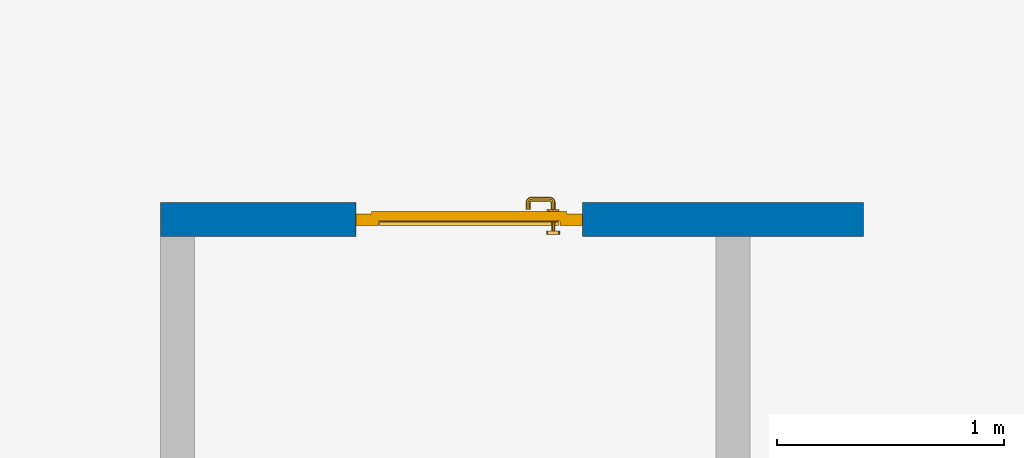
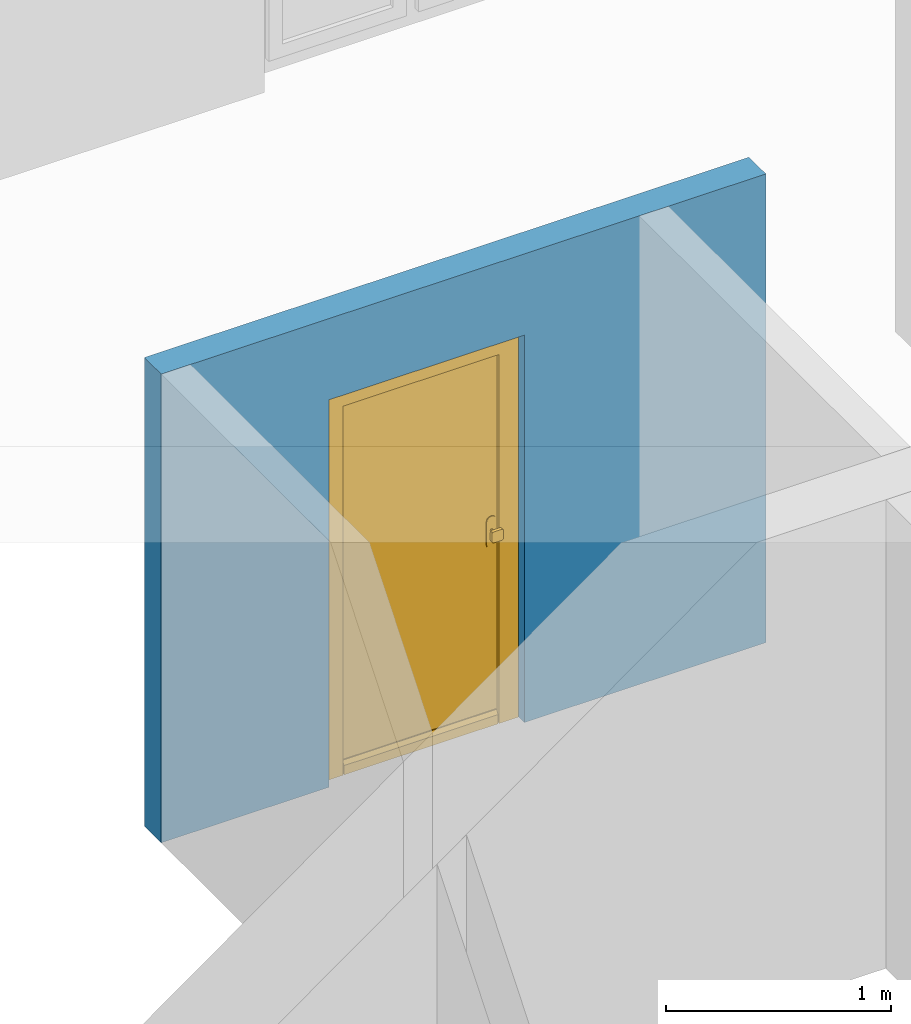
# One storey, part 11 of 48: 1 door, 1 wall, 1 opening.
"""IFC4 building model written with IfcOpenShell, lengths in metres."""

from ifc_helpers import new_model, entity, si_unit, converted_unit, derived_unit, direction, frame, origin_with_axes, place, context, subcontext, project, spatial, polygons, source, transform, mapped, material, type_object, element, fill, save


model = new_model("IFC4")

# Units and contexts
model_context = context("Model", 3, precision=1e-05, world=origin_with_axes(), true_north=direction((0.0, 1.0)))
body_context = subcontext(model_context, "Body", "Model", "MODEL_VIEW")
ifc_project = project(units=[si_unit("LENGTHUNIT", "METRE"), si_unit("AREAUNIT", "SQUARE_METRE"), si_unit("VOLUMEUNIT", "CUBIC_METRE"), converted_unit("PLANEANGLEUNIT", "DEGREE", entity("IfcPlaneAngleMeasure", 0.0174532925199), si_unit("PLANEANGLEUNIT", "RADIAN"), dimensions=[0, 0, 0, 0, 0, 0, 0]), converted_unit("TIMEUNIT", "Year", entity("IfcTimeMeasure", 31556926.0), si_unit("TIMEUNIT", "SECOND"), dimensions=[0, 0, 1, 0, 0, 0, 0]), si_unit("MASSUNIT", "GRAM", prefix="KILO"), si_unit("THERMODYNAMICTEMPERATUREUNIT", "DEGREE_CELSIUS"), si_unit("LUMINOUSINTENSITYUNIT", "LUMEN"), si_unit("ENERGYUNIT", "JOULE", prefix="MEGA"), derived_unit("THERMALCONDUCTANCEUNIT", [(si_unit("POWERUNIT", "WATT"), 1), (si_unit("LENGTHUNIT", "METRE"), -1), (si_unit("THERMODYNAMICTEMPERATUREUNIT", "KELVIN"), -1)]), derived_unit("SPECIFICHEATCAPACITYUNIT", [(si_unit("ENERGYUNIT", "JOULE"), 1), (si_unit("MASSUNIT", "GRAM", prefix="KILO"), -1), (si_unit("THERMODYNAMICTEMPERATUREUNIT", "KELVIN"), -1)]), derived_unit("MASSDENSITYUNIT", [(si_unit("MASSUNIT", "GRAM", prefix="KILO"), 1), (si_unit("VOLUMEUNIT", "CUBIC_METRE"), -1)])], contexts=[model_context])

# Site, building, storey
site_placement = place(None, origin_with_axes())
site = spatial("IfcSite", under=ifc_project, at=site_placement, CompositionType="ELEMENT")
building_placement = place(site_placement, origin_with_axes())
building = spatial("IfcBuilding", under=site, at=building_placement, CompositionType="ELEMENT")
storey_placement = place(building_placement, frame((0.0, 0.0, 3.4), z_axis=(0.0, 0.0, 1.0), x_axis=(1.0, 0.0, 0.0)))
storey = spatial("IfcBuildingStorey", under=building, at=storey_placement, Name="1. Geschoss", CompositionType="ELEMENT", Elevation=3.4)

# Wall, opening, door
ifc_material = material()
wall_type = type_object("IfcWallType", Name="150", PredefinedType="NOTDEFINED")
wall_placement = place(storey_placement, frame((-4.4421993804, 3.97118776896, 0.0), z_axis=(0.0, 0.0, 1.0), x_axis=(-1.0, 0.0, 0.0)))
wall = element("IfcWall", 1, at=wall_placement, inside=storey, type_object=wall_type, material=ifc_material, Name="Wand-002", PredefinedType="NOTDEFINED", context=body_context, shape_type="Tessellation", body=[
    polygons([(2.23891244988, 0.0, 2.1), (2.23891244988, 0.0, 0.0), (3.1, 0.0, 0.0), (3.1, 0.0, 2.54), (0.0, 0.0, 2.54), (0.0, 0.0, 0.0), (1.23891244988, 0.0, 0.0), (1.23891244988, 0.0, 2.1), (2.23891244988, 0.1, 2.1), (2.23891244988, 0.1, 0.0), (2.23891244988, 0.15, 0.0), (3.1, 0.15, 0.0), (3.1, 0.15, 2.54), (0.0, 0.15, 2.54), (0.0, 0.15, 0.0), (1.23891244988, 0.1, 0.0), (1.23891244988, 0.15, 0.0), (1.23891244988, 0.1, 2.1), (2.23891244988, 0.15, 2.1), (1.23891244988, 0.15, 2.1)], [[[1, 2, 3, 4, 5, 6, 7, 8]], [[2, 1, 9, 10]], [[2, 10, 11, 12, 3]], [[4, 3, 12, 13]], [[5, 4, 13, 14]], [[14, 15, 6, 5]], [[16, 7, 6, 15, 17]], [[8, 7, 16, 18]], [[1, 8, 18, 9]], [[10, 9, 19, 11]], [[12, 11, 19, 20, 17, 15, 14, 13]], [[18, 16, 17, 20]], [[9, 18, 20, 19]]], closed=True),
])
opening_placement = place(wall_placement, frame((1.73891244988, 0.0, 0.0), z_axis=(0.0, 0.0, 1.0), x_axis=(1.0, 0.0, 0.0)))
opening = element("IfcOpeningElement", 2, at=opening_placement, cuts=wall, context=body_context, identifier="Reference", shape_type="Tessellation", body=[
    polygons([(-0.5, 0.1, 0.0), (-0.5, 0.1, 2.1), (-0.5, 0.151, 2.1), (-0.5, 0.151, 0.0), (-0.5, -0.001, 0.0), (-0.5, -0.001, 2.1), (0.5, 0.1, 2.1), (0.5, 0.151, 2.1), (0.5, -0.001, 2.1), (0.5, 0.151, 0.0), (0.5, 0.1, 0.0), (0.5, -0.001, 0.0)], [[[1, 2, 3, 4]], [[2, 1, 5, 6]], [[7, 8, 3, 2, 6, 9]], [[8, 10, 4, 3]], [[1, 4, 10, 11, 12, 5]], [[6, 5, 12, 9]], [[7, 11, 10, 8]], [[11, 7, 9, 12]]], closed=True),
])
door_type = type_object("IfcDoorType", Name="Eingang 01 1-Fl 26", OperationType="SINGLE_SWING_LEFT", PredefinedType="DOOR")
shared_shape = source(origin_with_axes(), body_context, "Body", "Tessellation", [
    polygons([(-0.5, -0.05, 0.0), (-0.5, -0.05, 2.1), (-0.5, -0.03, 2.1), (-0.5, -0.03, 0.0), (-0.4, -0.05, 0.0), (-0.4, -0.05, 2.0), (-0.1301, -0.05, 2.0), (-0.0001, -0.05, 2.0), (0.4, -0.05, 2.0), (0.4, -0.05, 0.0), (0.5, -0.05, 0.0), (0.5, -0.05, 2.1), (0.5, -0.03, 2.1), (0.5, -0.03, 0.0), (0.4, -0.03, 0.0), (0.4, -0.03, 2.0), (-0.0001, -0.03, 2.0), (-0.1301, -0.03, 2.0), (-0.4, -0.03, 2.0), (-0.4, -0.03, 0.0)], [[[1, 2, 3, 4]], [[1, 5, 6, 7, 8, 9, 10, 11, 12, 2]], [[2, 12, 13, 3]], [[4, 3, 13, 14, 15, 16, 17, 18, 19, 20]], [[5, 1, 4, 20]], [[6, 5, 20, 19]], [[7, 6, 19, 18]], [[8, 7, 18, 17]], [[9, 8, 17, 16]], [[10, 9, 16, 15]], [[11, 10, 15, 14]], [[12, 11, 14, 13]]], closed=True),
    polygons([(-0.5, -0.03, 0.0), (-0.5, -0.03, 2.1), (-0.5, 0.0, 2.1), (-0.5, 0.0, 0.0), (-0.43, -0.03, 0.0), (-0.43, -0.03, 2.03), (-0.1001, -0.03, 2.03), (-0.0301, -0.03, 2.03), (0.43, -0.03, 2.03), (0.43, -0.03, 0.0), (0.5, -0.03, 0.0), (0.5, -0.03, 2.1), (0.5, 0.0, 2.1), (0.5, 0.0, 0.0), (0.43, 0.0, 0.0), (0.43, 0.0, 2.03), (-0.0301, 0.0, 2.03), (-0.1001, 0.0, 2.03), (-0.43, 0.0, 2.03), (-0.43, 0.0, 0.0)], [[[1, 2, 3, 4]], [[1, 5, 6, 7, 8, 9, 10, 11, 12, 2]], [[2, 12, 13, 3]], [[4, 3, 13, 14, 15, 16, 17, 18, 19, 20]], [[5, 1, 4, 20]], [[6, 5, 20, 19]], [[7, 6, 19, 18]], [[8, 7, 18, 17]], [[9, 8, 17, 16]], [[10, 9, 16, 15]], [[11, 10, 15, 14]], [[12, 11, 14, 13]]], closed=True),
    polygons([(-0.43, 0.01, 0.0), (-0.43, 0.01, 2.03), (0.43, 0.01, 2.03), (0.43, 0.01, 0.0), (-0.43, -0.03, 0.0), (-0.43, -0.03, 2.03), (0.43, -0.03, 2.03), (0.43, -0.03, 0.0)], [[[1, 2, 3, 4]], [[1, 5, 6, 2]], [[2, 6, 7, 3]], [[3, 7, 8, 4]], [[4, 8, 5, 1]], [[8, 7, 6, 5]]], closed=True),
    polygons([(-0.395, -0.05, 0.0), (0.395, -0.05, 0.0), (0.395, -0.05, 0.05), (-0.395, -0.05, 0.05), (-0.395, -0.03, 0.0), (0.395, -0.03, 0.0), (0.395, -0.03, 0.07), (0.395, -0.035, 0.07), (-0.395, -0.035, 0.07), (-0.395, -0.03, 0.07)], [[[1, 2, 3, 4]], [[5, 6, 2, 1]], [[2, 6, 7, 8, 3]], [[4, 3, 8, 9]], [[1, 4, 9, 10, 5]], [[10, 7, 6, 5]], [[9, 8, 7, 10]]], closed=True),
    polygons([(0.3835, 0.02, 1.0733826859), (0.37, 0.02, 1.077), (0.37, 0.0199, 1.077), (0.3835, 0.0199, 1.0733826859), (0.393382685902, 0.02, 1.0635), (0.397, 0.02, 1.05), (0.393382685902, 0.02, 1.0365), (0.3835, 0.02, 1.0266173141), (0.37, 0.02, 1.023), (0.3565, 0.02, 1.0266173141), (0.346617314098, 0.02, 1.0365), (0.343, 0.02, 1.05), (0.346617314098, 0.02, 1.0635), (0.3565, 0.02, 1.0733826859), (0.3565, 0.0199, 1.0733826859), (0.37, 0.0101, 1.077), (0.3835, 0.0101, 1.0733826859), (0.393382685902, 0.0199, 1.0635), (0.397, 0.0199, 1.05), (0.393382685902, 0.0199, 1.0365), (0.3835, 0.0199, 1.0266173141), (0.37, 0.0199, 1.023), (0.3565, 0.0199, 1.0266173141), (0.346617314098, 0.0199, 1.0365), (0.343, 0.0199, 1.05), (0.346617314098, 0.0199, 1.0635), (0.3565, 0.0101, 1.0733826859), (0.37, 0.01, 1.077), (0.3835, 0.01, 1.0733826859), (0.393382685902, 0.0101, 1.0635), (0.397, 0.0101, 1.05), (0.393382685902, 0.0101, 1.0365), (0.3835, 0.0101, 1.0266173141), (0.37, 0.0101, 1.023), (0.3565, 0.0101, 1.0266173141), (0.346617314098, 0.0101, 1.0365), (0.343, 0.0101, 1.05), (0.346617314098, 0.0101, 1.0635), (0.3565, 0.01, 1.0733826859), (0.346617314098, 0.01, 1.0635), (0.343, 0.01, 1.05), (0.346617314098, 0.01, 1.0365), (0.3565, 0.01, 1.0266173141), (0.37, 0.01, 1.023), (0.3835, 0.01, 1.0266173141), (0.393382685902, 0.01, 1.0365), (0.397, 0.01, 1.05), (0.393382685902, 0.01, 1.0635)], [[[1, 2, 3, 4]], [[2, 1, 5, 6, 7, 8, 9, 10, 11, 12, 13, 14]], [[2, 14, 15, 3]], [[4, 3, 16, 17]], [[5, 1, 4, 18]], [[6, 5, 18, 19]], [[7, 6, 19, 20]], [[8, 7, 20, 21]], [[9, 8, 21, 22]], [[10, 9, 22, 23]], [[11, 10, 23, 24]], [[12, 11, 24, 25]], [[13, 12, 25, 26]], [[14, 13, 26, 15]], [[3, 15, 27, 16]], [[17, 16, 28, 29]], [[18, 4, 17, 30]], [[19, 18, 30, 31]], [[20, 19, 31, 32]], [[21, 20, 32, 33]], [[22, 21, 33, 34]], [[23, 22, 34, 35]], [[24, 23, 35, 36]], [[25, 24, 36, 37]], [[26, 25, 37, 38]], [[15, 26, 38, 27]], [[16, 27, 39, 28]], [[28, 39, 40, 41, 42, 43, 44, 45, 46, 47, 48, 29]], [[30, 17, 29, 48]], [[31, 30, 48, 47]], [[32, 31, 47, 46]], [[33, 32, 46, 45]], [[34, 33, 45, 44]], [[35, 34, 44, 43]], [[36, 35, 43, 42]], [[37, 36, 42, 41]], [[38, 37, 41, 40]], [[27, 38, 40, 39]]], closed=True),
    polygons([(0.362532169224, 0.019, 0.959692280177), (0.363279754556, 0.019, 0.961639806549), (0.35705, 0.019, 0.972430057958), (0.347569942042, 0.019, 0.96295), (0.365, 0.019, 0.952886751346), (0.365, 0.019, 0.9544), (0.362532169224, 0.02, 0.959692280177), (0.363279754556, 0.02, 0.961639806549), (0.364624817685, 0.02, 0.965143815798), (0.364624817685, 0.019, 0.965143815798), (0.37, 0.019, 0.967425445323), (0.37, 0.019, 0.9759), (0.357, 0.019, 0.972516660498), (0.347483339502, 0.019, 0.963), (0.365, 0.019, 0.95), (0.3441, 0.019, 0.95), (0.365, 0.019, 0.947113248654), (0.365, 0.019, 0.941339745962), (0.365, 0.019, 0.9375), (0.365, 0.02, 0.9375), (0.365, 0.02, 0.941339745962), (0.365, 0.02, 0.947113248654), (0.365, 0.02, 0.95), (0.365, 0.02, 0.952886751346), (0.365, 0.02, 0.9544), (0.346703916638, 0.02, 0.96345), (0.35655, 0.02, 0.973296083362), (0.37, 0.02, 0.9769), (0.37, 0.02, 0.967425445323), (0.375375182315, 0.019, 0.965143815798), (0.376720245444, 0.019, 0.961639806549), (0.38295, 0.019, 0.972430057958), (0.37, 0.019, 0.976), (0.357, 0.0189, 0.972516660498), (0.347483339502, 0.0189, 0.963), (0.344, 0.019, 0.95), (0.347569942042, 0.019, 0.93705), (0.35705, 0.019, 0.927569942042), (0.37, 0.019, 0.9241), (0.37, 0.019, 0.9325), (0.366464466094, 0.019, 0.933964466094), (0.366464466094, 0.02, 0.933964466094), (0.37, 0.02, 0.9231), (0.35655, 0.02, 0.926703916638), (0.37, 0.02, 0.9325), (0.346703916638, 0.02, 0.93655), (0.3431, 0.02, 0.95), (0.346617314098, 0.02, 0.9635), (0.3565, 0.02, 0.973382685902), (0.37, 0.02, 0.977), (0.375375182315, 0.02, 0.965143815798), (0.38345, 0.02, 0.973296083362), (0.376720245444, 0.02, 0.961639806549), (0.377467830776, 0.02, 0.959692280177), (0.377467830776, 0.019, 0.959692280177), (0.375, 0.019, 0.9544), (0.375, 0.019, 0.952886751346), (0.392430057958, 0.019, 0.96295), (0.383, 0.019, 0.972516660498), (0.37, 0.0189, 0.976), (0.357, 0.0101, 0.972516660498), (0.347483339502, 0.0101, 0.963), (0.344, 0.0189, 0.95), (0.347483339502, 0.019, 0.937), (0.357, 0.019, 0.927483339502), (0.37, 0.019, 0.924), (0.38295, 0.019, 0.927569942042), (0.375, 0.019, 0.941339745962), (0.375, 0.019, 0.9375), (0.373535533906, 0.019, 0.933964466094), (0.37, 0.02, 0.923), (0.3565, 0.02, 0.926617314098), (0.38345, 0.02, 0.926703916638), (0.373535533906, 0.02, 0.933964466094), (0.375, 0.02, 0.9375), (0.375, 0.02, 0.941339745962), (0.346617314098, 0.02, 0.9365), (0.343, 0.02, 0.95), (0.346617314098, 0.0199, 0.9635), (0.3565, 0.0199, 0.973382685902), (0.37, 0.0199, 0.977), (0.3835, 0.02, 0.973382685902), (0.393296083362, 0.02, 0.96345), (0.375, 0.02, 0.952886751346), (0.375, 0.02, 0.9544), (0.375, 0.02, 0.95), (0.375, 0.02, 0.947113248654), (0.375, 0.019, 0.947113248654), (0.375, 0.019, 0.95), (0.3959, 0.019, 0.95), (0.392516660498, 0.019, 0.963), (0.383, 0.0189, 0.972516660498), (0.37, 0.0101, 0.976), (0.357, 0.01, 0.972516660498), (0.347483339502, 0.01, 0.963), (0.344, 0.0101, 0.95), (0.347483339502, 0.0189, 0.937), (0.357, 0.0189, 0.927483339502), (0.37, 0.0189, 0.924), (0.383, 0.019, 0.927483339502), (0.392430057958, 0.019, 0.93705), (0.37, 0.0199, 0.923), (0.3565, 0.0199, 0.926617314098), (0.3835, 0.02, 0.926617314098), (0.393296083362, 0.02, 0.93655), (0.346617314098, 0.0199, 0.9365), (0.343, 0.0199, 0.95), (0.346617314098, 0.0101, 0.9635), (0.3565, 0.0101, 0.973382685902), (0.37, 0.0101, 0.977), (0.3835, 0.0199, 0.973382685902), (0.393382685902, 0.02, 0.9635), (0.3969, 0.02, 0.95), (0.396, 0.019, 0.95), (0.392516660498, 0.0189, 0.963), (0.383, 0.0101, 0.972516660498), (0.37, 0.01, 0.976), (0.35695, 0.01, 0.972603263039), (0.347396736961, 0.01, 0.96305), (0.344, 0.01, 0.95), (0.347483339502, 0.0101, 0.937), (0.357, 0.0101, 0.927483339502), (0.37, 0.0101, 0.924), (0.383, 0.0189, 0.927483339502), (0.392516660498, 0.019, 0.937), (0.37, 0.0101, 0.923), (0.3565, 0.0101, 0.926617314098), (0.3835, 0.0199, 0.926617314098), (0.393382685902, 0.02, 0.9365), (0.346617314098, 0.0101, 0.9365), (0.343, 0.0101, 0.95), (0.346617314098, 0.01, 0.9635), (0.3565, 0.01, 0.973382685902), (0.37, 0.01, 0.977), (0.3835, 0.0101, 0.973382685902), (0.393382685902, 0.0199, 0.9635), (0.397, 0.02, 0.95), (0.396, 0.0189, 0.95), (0.392516660498, 0.0101, 0.963), (0.383, 0.01, 0.972516660498), (0.37, 0.01, 0.9761), (0.35655, 0.01, 0.973296083362), (0.346703916638, 0.01, 0.96345), (0.3439, 0.01, 0.95), (0.347483339502, 0.01, 0.937), (0.357, 0.01, 0.927483339502), (0.37, 0.01, 0.924), (0.383, 0.0101, 0.927483339502), (0.392516660498, 0.0189, 0.937), (0.37, 0.01, 0.923), (0.3565, 0.01, 0.926617314098), (0.3835, 0.0101, 0.926617314098), (0.393382685902, 0.0199, 0.9365), (0.346617314098, 0.01, 0.9365), (0.343, 0.01, 0.95), (0.37, 0.01, 0.9769), (0.3835, 0.01, 0.973382685902), (0.393382685902, 0.0101, 0.9635), (0.397, 0.0199, 0.95), (0.396, 0.0101, 0.95), (0.392516660498, 0.01, 0.963), (0.38305, 0.01, 0.972603263039), (0.3431, 0.01, 0.95), (0.347396736961, 0.01, 0.93695), (0.35695, 0.01, 0.927396736961), (0.37, 0.01, 0.9239), (0.383, 0.01, 0.927483339502), (0.392516660498, 0.0101, 0.937), (0.37, 0.01, 0.9231), (0.35655, 0.01, 0.926703916638), (0.3835, 0.01, 0.926617314098), (0.393382685902, 0.0101, 0.9365), (0.346703916638, 0.01, 0.93655), (0.38345, 0.01, 0.973296083362), (0.393382685902, 0.01, 0.9635), (0.397, 0.0101, 0.95), (0.396, 0.01, 0.95), (0.392603263039, 0.01, 0.96305), (0.38305, 0.01, 0.927396736961), (0.392516660498, 0.01, 0.937), (0.38345, 0.01, 0.926703916638), (0.393382685902, 0.01, 0.9365), (0.393296083362, 0.01, 0.96345), (0.397, 0.01, 0.95), (0.3961, 0.01, 0.95), (0.392603263039, 0.01, 0.93695), (0.393296083362, 0.01, 0.93655), (0.3969, 0.01, 0.95)], [[[1, 2, 3, 4, 5, 6]], [[1, 7, 8, 9, 10, 2]], [[10, 11, 12, 3, 2]], [[4, 3, 13, 14]], [[15, 5, 4, 16]], [[6, 5, 15, 17, 18, 19, 20, 21, 22, 23, 24, 25]], [[6, 25, 7, 1]], [[7, 25, 24, 26, 27, 8]], [[9, 8, 27, 28, 29]], [[10, 9, 29, 11]], [[30, 31, 32, 12, 11]], [[3, 12, 33, 13]], [[14, 13, 34, 35]], [[16, 4, 14, 36]], [[17, 15, 16, 37]], [[18, 17, 37, 38]], [[38, 39, 40, 41, 19, 18]], [[19, 41, 42, 20]], [[43, 44, 21, 20, 42, 45]], [[22, 21, 44, 46]], [[23, 22, 46, 47]], [[24, 23, 47, 26]], [[48, 49, 27, 26]], [[49, 50, 28, 27]], [[51, 29, 28, 52, 53]], [[11, 29, 51, 30]], [[30, 51, 53, 54, 55, 31]], [[55, 56, 57, 58, 32, 31]], [[12, 32, 59, 33]], [[13, 33, 60, 34]], [[35, 34, 61, 62]], [[36, 14, 35, 63]], [[37, 16, 36, 64]], [[38, 37, 64, 65]], [[39, 38, 65, 66]], [[39, 67, 68, 69, 70, 40]], [[41, 40, 45, 42]], [[71, 72, 44, 43]], [[73, 43, 45, 74, 75, 76]], [[72, 77, 46, 44]], [[77, 78, 47, 46]], [[78, 48, 26, 47]], [[79, 80, 49, 48]], [[80, 81, 50, 49]], [[50, 82, 52, 28]], [[54, 53, 52, 83, 84, 85]], [[55, 54, 85, 56]], [[85, 84, 86, 87, 76, 75, 69, 68, 88, 89, 57, 56]], [[57, 89, 90, 58]], [[32, 58, 91, 59]], [[33, 59, 92, 60]], [[34, 60, 93, 61]], [[62, 61, 94, 95]], [[63, 35, 62, 96]], [[64, 36, 63, 97]], [[65, 64, 97, 98]], [[66, 65, 98, 99]], [[67, 39, 66, 100]], [[88, 68, 67, 101]], [[70, 69, 75, 74]], [[40, 70, 74, 45]], [[102, 103, 72, 71]], [[104, 71, 43, 73]], [[76, 87, 105, 73]], [[103, 106, 77, 72]], [[106, 107, 78, 77]], [[107, 79, 48, 78]], [[108, 109, 80, 79]], [[109, 110, 81, 80]], [[81, 111, 82, 50]], [[82, 112, 83, 52]], [[86, 84, 83, 113]], [[87, 86, 113, 105]], [[89, 88, 101, 90]], [[58, 90, 114, 91]], [[59, 91, 115, 92]], [[60, 92, 116, 93]], [[61, 93, 117, 94]], [[95, 94, 118, 119]], [[96, 62, 95, 120]], [[97, 63, 96, 121]], [[98, 97, 121, 122]], [[99, 98, 122, 123]], [[100, 66, 99, 124]], [[101, 67, 100, 125]], [[126, 127, 103, 102]], [[128, 102, 71, 104]], [[129, 104, 73, 105]], [[127, 130, 106, 103]], [[130, 131, 107, 106]], [[131, 108, 79, 107]], [[132, 133, 109, 108]], [[133, 134, 110, 109]], [[110, 135, 111, 81]], [[111, 136, 112, 82]], [[112, 137, 113, 83]], [[137, 129, 105, 113]], [[90, 101, 125, 114]], [[91, 114, 138, 115]], [[92, 115, 139, 116]], [[93, 116, 140, 117]], [[94, 117, 141, 118]], [[119, 118, 142, 143]], [[120, 95, 119, 144]], [[121, 96, 120, 145]], [[122, 121, 145, 146]], [[123, 122, 146, 147]], [[124, 99, 123, 148]], [[125, 100, 124, 149]], [[150, 151, 127, 126]], [[152, 126, 102, 128]], [[153, 128, 104, 129]], [[151, 154, 130, 127]], [[154, 155, 131, 130]], [[155, 132, 108, 131]], [[143, 142, 133, 132]], [[142, 156, 134, 133]], [[134, 157, 135, 110]], [[135, 158, 136, 111]], [[136, 159, 137, 112]], [[159, 153, 129, 137]], [[114, 125, 149, 138]], [[115, 138, 160, 139]], [[116, 139, 161, 140]], [[117, 140, 162, 141]], [[118, 141, 156, 142]], [[144, 119, 143, 163]], [[145, 120, 144, 164]], [[146, 145, 164, 165]], [[147, 146, 165, 166]], [[148, 123, 147, 167]], [[149, 124, 148, 168]], [[169, 170, 151, 150]], [[171, 150, 126, 152]], [[172, 152, 128, 153]], [[170, 173, 154, 151]], [[173, 163, 155, 154]], [[163, 143, 132, 155]], [[156, 174, 157, 134]], [[157, 175, 158, 135]], [[158, 176, 159, 136]], [[176, 172, 153, 159]], [[138, 149, 168, 160]], [[139, 160, 177, 161]], [[140, 161, 178, 162]], [[141, 162, 174, 156]], [[164, 144, 163, 173]], [[165, 164, 173, 170]], [[166, 165, 170, 169]], [[167, 147, 166, 179]], [[168, 148, 167, 180]], [[181, 169, 150, 171]], [[182, 171, 152, 172]], [[174, 183, 175, 157]], [[175, 184, 176, 158]], [[184, 182, 172, 176]], [[160, 168, 180, 177]], [[161, 177, 185, 178]], [[162, 178, 183, 174]], [[179, 166, 169, 181]], [[180, 167, 179, 186]], [[187, 181, 171, 182]], [[183, 188, 184, 175]], [[188, 187, 182, 184]], [[177, 180, 186, 185]], [[178, 185, 188, 183]], [[186, 179, 181, 187]], [[185, 186, 187, 188]]], closed=True),
    polygons([(0.38, 0.02, 1.05), (0.377071067812, 0.02, 1.04292893219), (0.377071067812, 0.050696439392, 1.04292893219), (0.38, 0.0509849140336, 1.05), (0.37, 0.02, 1.04), (0.37, 0.05, 1.04), (0.375518993221, 0.0584992452783, 1.04292893219), (0.378277987014, 0.0596420579258, 1.05), (0.377071067812, 0.02, 1.05707106781), (0.377071067812, 0.050696439392, 1.05707106781), (0.362928932188, 0.02, 1.04292893219), (0.362928932188, 0.049303560608, 1.04292893219), (0.368858192988, 0.0557402514855, 1.04), (0.370704557509, 0.0657045575088, 1.04292893219), (0.372816199938, 0.0678161999379, 1.05), (0.375518993221, 0.0584992452783, 1.05707106781), (0.37, 0.02, 1.06), (0.37, 0.05, 1.06), (0.36, 0.02, 1.05), (0.36, 0.0490150859664, 1.05), (0.362197392755, 0.0529812576926, 1.04292893219), (0.365606601718, 0.0606066017178, 1.04), (0.363499245278, 0.0705189932208, 1.04292893219), (0.364642057926, 0.0732779870137, 1.05), (0.370704557509, 0.0657045575088, 1.05707106781), (0.368858192988, 0.0557402514855, 1.06), (0.362928932188, 0.02, 1.05707106781), (0.362928932188, 0.049303560608, 1.05707106781), (0.359438398962, 0.0518384450452, 1.05), (0.360508645927, 0.0555086459268, 1.04292893219), (0.360740251485, 0.0638581929877, 1.04), (0.355696439392, 0.0720710678119, 1.04292893219), (0.355984914034, 0.075, 1.05), (0.363499245278, 0.0705189932208, 1.05707106781), (0.365606601718, 0.0606066017178, 1.06), (0.362197392755, 0.0529812576926, 1.05707106781), (0.358397003498, 0.0533970034977, 1.05), (0.357981257693, 0.0571973927545, 1.04292893219), (0.355, 0.065, 1.04), (0.274303560608, 0.0720710678119, 1.04292893219), (0.274015085966, 0.075, 1.05), (0.355696439392, 0.0720710678119, 1.05707106781), (0.360740251485, 0.0638581929877, 1.06), (0.360508645927, 0.0555086459268, 1.05707106781), (0.356838445045, 0.0544383989617, 1.05), (0.354303560608, 0.0579289321881, 1.04292893219), (0.275, 0.065, 1.04), (0.266500754722, 0.0705189932208, 1.04292893219), (0.265357942074, 0.0732779870137, 1.05), (0.274303560608, 0.0720710678119, 1.05707106781), (0.355, 0.065, 1.06), (0.357981257693, 0.0571973927545, 1.05707106781), (0.354015085966, 0.055, 1.05), (0.275696439392, 0.0579289321881, 1.04292893219), (0.269259748515, 0.0638581929877, 1.04), (0.259295442491, 0.0657045575088, 1.04292893219), (0.257183800062, 0.0678161999379, 1.05), (0.266500754722, 0.0705189932208, 1.05707106781), (0.275, 0.065, 1.06), (0.354303560608, 0.0579289321881, 1.05707106781), (0.275984914034, 0.055, 1.05), (0.272018742307, 0.0571973927545, 1.04292893219), (0.264393398282, 0.0606066017178, 1.04), (0.254481006779, 0.0584992452783, 1.04292893219), (0.251722012986, 0.0596420579258, 1.05), (0.259295442491, 0.0657045575088, 1.05707106781), (0.269259748515, 0.0638581929877, 1.06), (0.275696439392, 0.0579289321881, 1.05707106781), (0.273161554955, 0.0544383989617, 1.05), (0.269491354073, 0.0555086459268, 1.04292893219), (0.261141807012, 0.0557402514855, 1.04), (0.252928932188, 0.050696439392, 1.04292893219), (0.25, 0.0509849140336, 1.05), (0.254481006779, 0.0584992452783, 1.05707106781), (0.264393398282, 0.0606066017178, 1.06), (0.272018742307, 0.0571973927545, 1.05707106781), (0.271602996502, 0.0533970034977, 1.05), (0.267802607245, 0.0529812576926, 1.04292893219), (0.26, 0.05, 1.04), (0.252928932188, 0.02, 1.04292893219), (0.25, 0.02, 1.05), (0.252928932188, 0.050696439392, 1.05707106781), (0.261141807012, 0.0557402514855, 1.06), (0.269491354073, 0.0555086459268, 1.05707106781), (0.270561601038, 0.0518384450452, 1.05), (0.267071067812, 0.049303560608, 1.04292893219), (0.26, 0.02, 1.04), (0.267071067812, 0.02, 1.04292893219), (0.27, 0.02, 1.05), (0.267071067812, 0.02, 1.05707106781), (0.26, 0.02, 1.06), (0.252928932188, 0.02, 1.05707106781), (0.26, 0.05, 1.06), (0.267802607245, 0.0529812576926, 1.05707106781), (0.27, 0.0490150859664, 1.05), (0.267071067812, 0.049303560608, 1.05707106781)], [[[1, 2, 3, 4]], [[2, 5, 6, 3]], [[4, 3, 7, 8]], [[9, 1, 4, 10]], [[5, 11, 12, 6]], [[3, 6, 13, 7]], [[8, 7, 14, 15]], [[10, 4, 8, 16]], [[17, 9, 10, 18]], [[11, 19, 20, 12]], [[6, 12, 21, 13]], [[7, 13, 22, 14]], [[15, 14, 23, 24]], [[16, 8, 15, 25]], [[18, 10, 16, 26]], [[27, 17, 18, 28]], [[19, 27, 28, 20]], [[12, 20, 29, 21]], [[13, 21, 30, 22]], [[14, 22, 31, 23]], [[24, 23, 32, 33]], [[25, 15, 24, 34]], [[26, 16, 25, 35]], [[28, 18, 26, 36]], [[20, 28, 36, 29]], [[21, 29, 37, 30]], [[22, 30, 38, 31]], [[23, 31, 39, 32]], [[33, 32, 40, 41]], [[34, 24, 33, 42]], [[35, 25, 34, 43]], [[36, 26, 35, 44]], [[29, 36, 44, 37]], [[30, 37, 45, 38]], [[31, 38, 46, 39]], [[32, 39, 47, 40]], [[41, 40, 48, 49]], [[42, 33, 41, 50]], [[43, 34, 42, 51]], [[44, 35, 43, 52]], [[37, 44, 52, 45]], [[38, 45, 53, 46]], [[39, 46, 54, 47]], [[40, 47, 55, 48]], [[49, 48, 56, 57]], [[50, 41, 49, 58]], [[51, 42, 50, 59]], [[52, 43, 51, 60]], [[45, 52, 60, 53]], [[46, 53, 61, 54]], [[47, 54, 62, 55]], [[48, 55, 63, 56]], [[57, 56, 64, 65]], [[58, 49, 57, 66]], [[59, 50, 58, 67]], [[60, 51, 59, 68]], [[53, 60, 68, 61]], [[54, 61, 69, 62]], [[55, 62, 70, 63]], [[56, 63, 71, 64]], [[65, 64, 72, 73]], [[66, 57, 65, 74]], [[67, 58, 66, 75]], [[68, 59, 67, 76]], [[61, 68, 76, 69]], [[62, 69, 77, 70]], [[63, 70, 78, 71]], [[64, 71, 79, 72]], [[73, 72, 80, 81]], [[74, 65, 73, 82]], [[75, 66, 74, 83]], [[76, 67, 75, 84]], [[69, 76, 84, 77]], [[70, 77, 85, 78]], [[71, 78, 86, 79]], [[72, 79, 87, 80]], [[81, 80, 87, 88, 89, 90, 91, 92]], [[82, 73, 81, 92]], [[83, 74, 82, 93]], [[84, 75, 83, 94]], [[77, 84, 94, 85]], [[78, 85, 95, 86]], [[79, 86, 88, 87]], [[86, 95, 89, 88]], [[95, 96, 90, 89]], [[96, 93, 91, 90]], [[93, 82, 92, 91]], [[94, 83, 93, 96]], [[85, 94, 96, 95]]], closed=False),
    polygons([(0.364696699141, -0.035, 1.04469669914), (0.3625, -0.035, 1.05), (0.364696699141, -0.035, 1.05530330086), (0.37, -0.035, 1.0575), (0.375303300859, -0.035, 1.05530330086), (0.3775, -0.035, 1.05), (0.375303300859, -0.035, 1.04469669914), (0.37, -0.035, 1.0425), (0.364696699141, -0.075, 1.04469669914), (0.3625, -0.075, 1.05), (0.364696699141, -0.075, 1.05530330086), (0.37, -0.075, 1.0575), (0.375303300859, -0.075, 1.05530330086), (0.3775, -0.075, 1.05), (0.375303300859, -0.075, 1.04469669914), (0.37, -0.075, 1.0425)], [[[1, 2, 3, 4, 5, 6, 7, 8]], [[1, 9, 10, 2]], [[2, 10, 11, 3]], [[3, 11, 12, 4]], [[4, 12, 13, 5]], [[5, 13, 14, 6]], [[6, 14, 15, 7]], [[7, 15, 16, 8]], [[8, 16, 9, 1]], [[9, 16, 15, 14, 13, 12, 11, 10]]], closed=True),
    polygons([(0.395, -0.03, 0.975), (0.395, -0.035, 0.975), (0.393096988313, -0.035, 0.965432914191), (0.393096988313, -0.03, 0.965432914191), (0.395, -0.03, 1.1), (0.395, -0.035, 1.1), (0.393096988313, -0.035, 1.10956708581), (0.38767766953, -0.035, 1.11767766953), (0.379567085809, -0.035, 1.12309698831), (0.37, -0.035, 1.125), (0.360432914191, -0.035, 1.12309698831), (0.35232233047, -0.035, 1.11767766953), (0.346903011687, -0.035, 1.10956708581), (0.345, -0.035, 1.1), (0.345, -0.035, 0.975), (0.346903011687, -0.035, 0.965432914191), (0.35232233047, -0.035, 0.95732233047), (0.360432914191, -0.035, 0.951903011687), (0.37, -0.035, 0.95), (0.379567085809, -0.035, 0.951903011687), (0.38767766953, -0.035, 0.95732233047), (0.38767766953, -0.03, 0.95732233047), (0.379567085809, -0.03, 0.951903011687), (0.37, -0.03, 0.95), (0.360432914191, -0.03, 0.951903011687), (0.35232233047, -0.03, 0.95732233047), (0.346903011687, -0.03, 0.965432914191), (0.345, -0.03, 0.975), (0.345, -0.03, 1.1), (0.346903011687, -0.03, 1.10956708581), (0.35232233047, -0.03, 1.11767766953), (0.360432914191, -0.03, 1.12309698831), (0.37, -0.03, 1.125), (0.379567085809, -0.03, 1.12309698831), (0.38767766953, -0.03, 1.11767766953), (0.393096988313, -0.03, 1.10956708581)], [[[1, 2, 3, 4]], [[5, 6, 2, 1]], [[2, 6, 7, 8, 9, 10, 11, 12, 13, 14, 15, 16, 17, 18, 19, 20, 21, 3]], [[4, 3, 21, 22]], [[1, 4, 22, 23, 24, 25, 26, 27, 28, 29, 30, 31, 32, 33, 34, 35, 36, 5]], [[36, 7, 6, 5]], [[35, 8, 7, 36]], [[34, 9, 8, 35]], [[33, 10, 9, 34]], [[32, 11, 10, 33]], [[31, 12, 11, 32]], [[30, 13, 12, 31]], [[29, 14, 13, 30]], [[28, 15, 14, 29]], [[27, 16, 15, 28]], [[26, 17, 16, 27]], [[25, 18, 17, 26]], [[24, 19, 18, 25]], [[23, 20, 19, 24]], [[22, 21, 20, 23]]], closed=True),
    polygons([(0.39, -0.075, 1.08), (0.39, -0.09, 1.08), (0.395, -0.09, 1.07866025404), (0.395, -0.075, 1.07866025404), (0.35, -0.075, 1.08), (0.35, -0.09, 1.08), (0.345, -0.09, 1.07866025404), (0.341339745962, -0.09, 1.075), (0.34, -0.09, 1.07), (0.34, -0.09, 1.03), (0.341339745962, -0.09, 1.025), (0.345, -0.09, 1.02133974596), (0.35, -0.09, 1.02), (0.39, -0.09, 1.02), (0.395, -0.09, 1.02133974596), (0.398660254038, -0.09, 1.025), (0.4, -0.09, 1.03), (0.4, -0.09, 1.07), (0.398660254038, -0.09, 1.075), (0.398660254038, -0.075, 1.075), (0.4, -0.075, 1.07), (0.4, -0.075, 1.03), (0.398660254038, -0.075, 1.025), (0.395, -0.075, 1.02133974596), (0.39, -0.075, 1.02), (0.35, -0.075, 1.02), (0.345, -0.075, 1.02133974596), (0.341339745962, -0.075, 1.025), (0.34, -0.075, 1.03), (0.34, -0.075, 1.07), (0.341339745962, -0.075, 1.075), (0.345, -0.075, 1.07866025404)], [[[1, 2, 3, 4]], [[5, 6, 2, 1]], [[2, 6, 7, 8, 9, 10, 11, 12, 13, 14, 15, 16, 17, 18, 19, 3]], [[4, 3, 19, 20]], [[1, 4, 20, 21, 22, 23, 24, 25, 26, 27, 28, 29, 30, 31, 32, 5]], [[32, 7, 6, 5]], [[31, 8, 7, 32]], [[30, 9, 8, 31]], [[29, 10, 9, 30]], [[28, 11, 10, 29]], [[27, 12, 11, 28]], [[26, 13, 12, 27]], [[25, 14, 13, 26]], [[24, 15, 14, 25]], [[23, 16, 15, 24]], [[22, 17, 16, 23]], [[21, 18, 17, 22]], [[20, 19, 18, 21]]], closed=True),
])
door_placement = place(opening_placement, frame((0.4, 0.0, 0.0), z_axis=(0.0, 0.0, 1.0), x_axis=(-1.0, 0.0, 0.0)))
door = element("IfcDoor", 3, at=door_placement, inside=storey, type_object=door_type, OverallHeight=2.1, OverallWidth=1.0, PredefinedType="DOOR", context=body_context, shape_type="MappedRepresentation", body=[
    mapped(shared_shape, transform((0.4, -0.05, 0.0))),
])
fill(opening, door)

save(model, "model.ifc")
